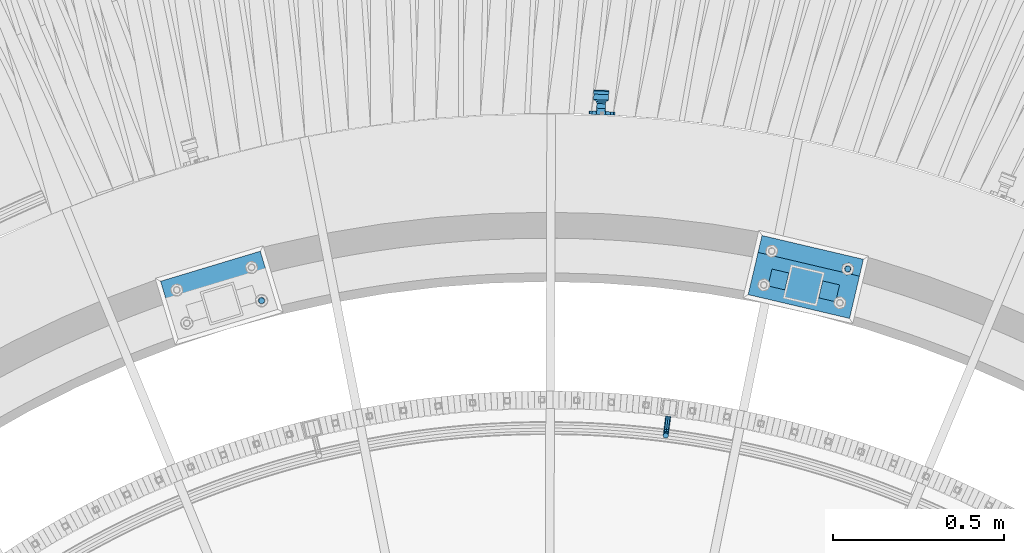
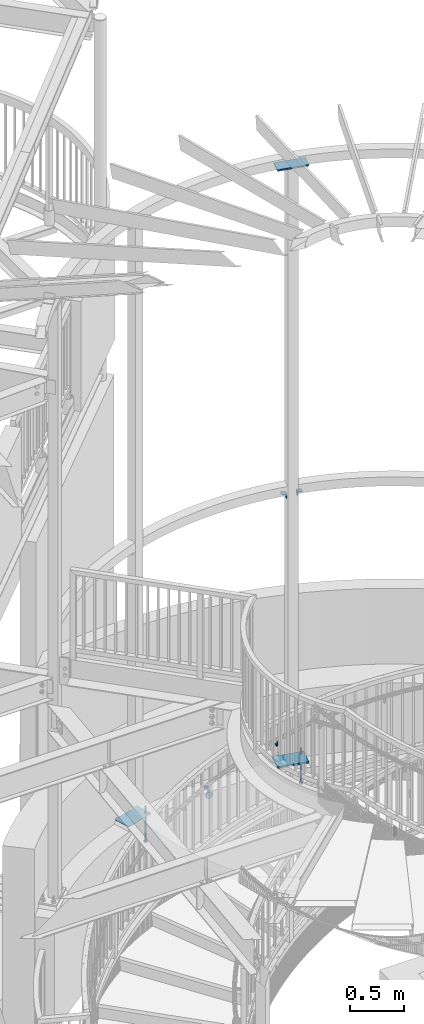
# One storey, part 516 of 975: 9 beams.
"""IFC2X3 building model written with IfcOpenShell, lengths in millimetres."""

from ifc_helpers import new_model, si_unit, frame, origin_with_axes, place, context, subcontext, project, spatial, faceted_brep, material, type_object, element, save


model = new_model("IFC2X3")

# Units and contexts
model_context = context("Model", 3, precision=1e-05, world=origin_with_axes())
body_context = subcontext(model_context, "Body", "Model", "MODEL_VIEW")
ifc_project = project(units=[si_unit("LENGTHUNIT", "METRE", prefix="MILLI"), si_unit("AREAUNIT", "SQUARE_METRE"), si_unit("VOLUMEUNIT", "CUBIC_METRE"), si_unit("MASSUNIT", "GRAM", prefix="KILO"), si_unit("TIMEUNIT", "SECOND"), si_unit("PLANEANGLEUNIT", "RADIAN"), si_unit("SOLIDANGLEUNIT", "STERADIAN"), si_unit("THERMODYNAMICTEMPERATUREUNIT", "DEGREE_CELSIUS"), si_unit("LUMINOUSINTENSITYUNIT", "LUMEN")], contexts=[model_context])

# Site, building, storey
site_placement = place(None, origin_with_axes())
site = spatial("IfcSite", under=ifc_project, at=site_placement, CompositionType="ELEMENT")
building_placement = place(site_placement, origin_with_axes())
building = spatial("IfcBuilding", under=site, at=building_placement, Name="Undefined", CompositionType="ELEMENT")
storey_placement = place(building_placement, origin_with_axes())
storey = spatial("IfcBuildingStorey", under=building, at=storey_placement, Name="Undefined", CompositionType="ELEMENT", Elevation=0.0)

# Beams
ifc_material_1 = material(Name="STEEL/A36")
beam_type_1 = type_object("IfcBeamType", PredefinedType="NOTDEFINED")
beam_1_placement = place(storey_placement, frame((35090.0909619197, 6226.08863746307, 1991.9523874386), z_axis=(0.0, 0.0, 1.0), x_axis=(-0.12548021699091, -0.992096121927666, 0.0)))
element("IfcBeam", 1, at=beam_1_placement, inside=storey, type_object=beam_type_1, material=ifc_material_1, Name="BRACKET", context=body_context, shape_type="Brep", body=[
    faceted_brep([(-4.22995071858168e-07, -7.93750000000728, 0.0), (-2.99107341561466e-07, -5.61266007567065, -5.61266007566792), (31.7499842270954, -5.6126618385606, -5.6126600757234), (31.7499840980236, -7.93750176289177, -5.54791768081486e-11), (-1.09139364212751e-11, 1.81898940354586e-12, -7.9375), (31.7499845387247, -1.7628881323617e-06, -7.93750000005548), (2.99089151667431e-07, 5.61266007567428, -5.61266007566792), (31.7499848503612, 5.61265831278433, -5.6126600757234), (4.22980519942939e-07, 7.93750000001091, 0.0), (31.7499849794513, 7.93749823711914, -5.54791768081486e-11), (2.99089151667431e-07, 5.61266007567428, 5.61266007566792), (31.7499848503794, 5.61265831278433, 5.61266007561244), (-1.09139364212751e-11, 1.81898940354586e-12, 7.9375), (31.7499845387538, -1.7628881323617e-06, 7.93749999994452), (-2.99107341561466e-07, -5.61266007567065, 5.61266007566792), (31.7499842271172, -5.6126618385606, 5.61266007561244), (44.5076933192395, -2.47124626184814e-06, -5.39983394420233), (43.618015285665, -5.61266249752225, -3.25196192174644), (41.4701431341346, -7.93750230259684, 1.9334598451087), (39.322271240766, -5.61266225900181, 7.11888161196475), (38.432593830461, -2.1339365048334e-06, 9.26675363442064), (39.3222718640282, 5.61265789233948, 7.11888161196475), (41.4701440155623, 7.93749769741771, 1.9334598451087), (43.6180159089272, 5.61265765382268, -3.25196192174644), (53.6792468227941, 5.61265709518557, 3.47073764605557), (55.32315658683, -3.07176742353477e-06, 1.82682757038583), (49.7104969518768, 7.93749723988003, 7.43948764606012), (45.7417468228014, 5.61265753590487, 11.4082376460638), (44.0978364355033, -2.44848706643097e-06, 13.0521477217335), (45.7417461995356, -5.61266261544006, 11.4082376460638), (49.7104960704528, -7.93750276013816, 7.43948764606012), (53.6792461995283, -5.612663056163, 3.47073764605648), (60.4019463906188, 5.61265672191075, 13.5319685599115), (62.5498181014409, -3.47302193404175e-06, 12.6422908379673), (55.2165247528465, 7.93749693416248, 15.6798405823693), (50.0311028569122, 5.61265729774459, 17.8277126048279), (47.8832305228243, -2.65866765403189e-06, 18.7173903267721), (50.03110223365, -5.61266285360034, 17.8277126048279), (55.2165238714188, -7.93750306585207, 15.6798405823693), (60.4019457673567, -5.61266342943782, 13.5319685599115), (62.7626445446149, 5.61265659083438, 25.3999996184748), (65.0874841573168, -3.61392449121922e-06, 25.3999996184748), (57.1499845980288, 7.93749682680573, 25.3999996184748), (51.5373243932772, 5.61265721410746, 25.3999996184748), (49.2124841573132, -2.73247496807016e-06, 25.3999996184748), (51.5373237700151, -5.61266293723384, 25.3999996184748), (57.1499837166011, -7.93750317320519, 25.3999996184748), (62.7626439213527, -5.61266356051055, 25.3999996184748), (65.0874827799671, -8.13710357761011e-07, 63.5532656203741), (62.7626427854739, -5.61266086031537, 61.7133802904182), (57.1499826807376, -7.93750071448449, 60.9512776088477), (51.5373226341253, -5.61266071998034, 61.7133869906074), (49.2124827799453, -6.15244061918929e-07, 63.5532750958728), (51.5373227744385, 5.61265943136095, 65.3931604258296), (57.1499828791711, 7.93749928552643, 66.1552631073992), (62.7626429257907, 5.61265929102228, 65.3931537256394)], [[[0, 1, 2, 3]], [[1, 4, 5, 2]], [[4, 6, 7, 5]], [[6, 8, 9, 7]], [[8, 10, 11, 9]], [[10, 12, 13, 11]], [[12, 14, 15, 13]], [[14, 0, 3, 15]], [[14, 12, 10, 8, 6, 4, 1, 0]], [[2, 5, 16, 17]], [[3, 2, 17, 18]], [[15, 3, 18, 19]], [[13, 15, 19, 20]], [[11, 13, 20, 21]], [[9, 11, 21, 22]], [[7, 9, 22, 23]], [[5, 7, 23, 16]], [[23, 24, 25, 16]], [[22, 26, 24, 23]], [[21, 27, 26, 22]], [[20, 28, 27, 21]], [[19, 29, 28, 20]], [[18, 30, 29, 19]], [[17, 31, 30, 18]], [[16, 25, 31, 17]], [[24, 32, 33, 25]], [[26, 34, 32, 24]], [[27, 35, 34, 26]], [[28, 36, 35, 27]], [[29, 37, 36, 28]], [[30, 38, 37, 29]], [[31, 39, 38, 30]], [[25, 33, 39, 31]], [[32, 40, 41, 33]], [[34, 42, 40, 32]], [[35, 43, 42, 34]], [[36, 44, 43, 35]], [[37, 45, 44, 36]], [[38, 46, 45, 37]], [[39, 47, 46, 38]], [[33, 41, 47, 39]], [[47, 41, 48, 49]], [[46, 47, 49, 50]], [[45, 46, 50, 51]], [[44, 45, 51, 52]], [[43, 44, 52, 53]], [[42, 43, 53, 54]], [[40, 42, 54, 55]], [[41, 40, 55, 48]], [[54, 53, 52, 51, 50, 49, 48, 55]]]),
])
beam_type_2 = type_object("IfcBeamType", PredefinedType="NOTDEFINED")
beam_2_placement = place(storey_placement, frame((34896.7817644496, 7118.03903297285, 938.701999049643), z_axis=(-0.996269882339371, 0.0421903820143261, -0.0752747846823936), x_axis=(-0.0423124779877496, -0.999104425706037, 2.72239999873893e-05)))
element("IfcBeam", 2, at=beam_2_placement, inside=storey, type_object=beam_type_2, material=ifc_material_1, Name="WALL BRACKET", context=body_context, shape_type="Brep", body=[
    faceted_brep([(-1.09139364212751e-11, -35.1998101886752, 14.5802387730655), (0.0, -26.940768363208, 26.9407683632162), (1.2732925824821e-11, -14.5802387731151, 35.1998101887366), (0.0, 0.0, 38.0999984741211), (3.27418092638254e-11, 14.5802387730973, 35.1998101888166), (3.45607986673713e-11, 26.9407683631939, 26.9407683633472), (3.27418092638254e-11, 35.1998101886679, 14.5802387732328), (2.36468622460961e-11, 38.0999999999908, 8.73114913702011e-11), (1.45519152283669e-11, 35.1998101886752, -14.5802387730655), (1.81898940354586e-12, 26.9407683632071, -26.9407683632162), (-1.09139364212751e-11, 14.5802387731146, -35.1998101887511), (0.0, 0.0, -38.0999984741211), (-2.91038304567337e-11, -14.5802387730978, -35.1998101888239), (-3.27418092638254e-11, -26.9407683631948, -26.9407683633617), (-3.09228198602796e-11, -35.1998101886688, -14.5802387732401), (-2.36468622460961e-11, -38.0999999999917, -9.45874489843845e-11), (9.52499999999407, 35.4440469783465, 13.3523775149006), (9.52500000001783, 38.099999999989, 1.23691279441118e-10), (5.45819490078651, 35.1998101886775, 14.58023877304), (5.15915812204861, 35.4440469814256, 13.3523774994246), (5.15916016817869, 35.4440461871586, -13.3523814925829), (5.45819607316758, 35.1998101886757, -14.5802387731565), (9.52499999563867, 35.4440461839649, -13.352381508641), (9.52499999999338, 33.7468954266617, -16.754679378646), (9.52499999999418, 26.9407683632057, -26.9407683631944), (7.23710514487385, 33.7468954167059, -16.7546793935435), (9.52499999997963, 14.5802387731133, -35.199810188722), (9.52499999996871, 7.73070496506989e-12, -38.1000000000931), (9.52499999996326, -14.5802387730996, -35.1998101888021), (9.52499999995962, -26.9407683631966, -26.9407683633399), (9.5249999999578, -35.1998101886768, -14.5802387731064), (9.52499999997235, -38.0999999999935, -7.27595761418343e-11), (9.52499999988504, -35.1998101886779, 14.5802387731401), (9.52499999999418, -26.9407683632098, 26.940768363238), (9.52500000000691, -14.5802387731169, 35.1998101887584), (9.52500000001783, -1.13686837721616e-11, 38.1000000001295), (9.5250000000251, 14.580238773096, 35.1998101888312), (9.52500000002692, 26.9407683631925, 26.9407683633617), (7.23710629084189, 33.7468933804012, 16.7546824409801), (9.52500001802099, 33.74689339, 16.7546824266137), (4.12737783423069, 36.2867482851609, 11.6630037101459), (9.52500001480979, 36.2867482910076, 11.6630037099276), (1.9072828969438, 38.0999998001848, -4.3824766180478e-06), (9.43529109937867, 38.0999998083389, -4.38277129433118e-06), (4.12738199474541, 36.2867456530334, -11.6630120660157), (9.52499999713365, 36.2867456588801, -11.6630120662267), (9.52499998931302, 31.8782691818908, -20.5007361535354), (1.90728516843444, 38.0999984362613, -14.9620414784949), (9.43529504267332, 38.0999984471014, -14.9620414798228), (9.52499998867484, 31.8782692100656, -21.3428983101403), (-0.974480980704527, 40.4536660864392, -13.6176374922397), (6.55352889353486, 40.4536660972792, -13.617637493564), (-3.23293929398841, 48.4467136552532, -12.2071016444133), (-3.86099316375032, 48.9596734302611, -12.3332393299024), (-3.86099415506237, 48.9596734359397, 12.1506042690053), (-3.23294234398753, 48.4467162038179, 12.0244673261113), (6.55352388489973, 40.4536689343606, 13.4350048968336), (9.4352891744017, 38.1000015670843, 14.7794093900302), (-8.88876894391092, 51.462646060533, -12.9487245784876), (-14.5044020842531, 51.5524567377918, -12.9708091785214), (-14.5044031272276, 51.5524567437842, 12.788173508583), (-8.88876998507754, 51.4626460665079, 12.7660889411018), (-16.4483770195459, 51.1442726592504, -12.8704360163174), (-16.4483780543928, 51.1442726651987, 12.6878004343525), (-22.5793182144077, 51.3711360271759, -12.9262221073186), (-22.5793192537777, 51.3711360331463, 12.7435864607032), (-27.8885284154861, 54.4455780358899, -13.6822326528272), (-27.8885295160832, 54.4455780422152, 13.4995963000001), (-28.6196515649072, 55.6169452716154, -13.9702738582564), (-31.1370083013608, 59.6501226213948, -17.5950925222933), (-31.1370097188383, 59.6501226295447, 17.4124524185645), (-28.6196545294583, 55.616948227025, 13.7876379643458), (-33.6296792490059, 67.324805151891, -22.2250062266612), (-32.8101722890036, 64.8016260361878, -22.2250061928717), (-39.3161821982224, 64.9509398614337, -22.2250064563596), (-33.6296810489844, 67.3248051619378, 22.2249937734341), (-39.3127719838823, 64.95236112884, 22.2249935438595), (-32.8101756191698, 64.8016307577993, 22.2249938072164), (-49.8281982508399, 63.7590297560901, -21.2879733583577), (-49.8281999673757, 63.7590297658239, 21.1053316176076), (-62.537662592724, 64.8016282183019, -22.2250073966388), (-62.5376643923654, 64.8016282284259, 22.2249926034456), (-59.3629825026719, 68.3509998487543, 22.2249927311568), (-59.3629807030303, 68.3509998386305, -22.2250072689349), (-56.0005505059879, 61.6533412669896, 22.2249928688907), (-56.0009816237271, 61.6535489521873, 19.2130312653135), (-56.0009816302269, 64.8016307505561, 22.0423689734525), (-51.9930603186979, 64.8016307660225, 22.2249930304133), (-51.9930486616773, 64.8016260085653, -22.2250069696784), (-56.000981616694, 61.6535497473442, -22.2250071312228), (-56.0009816212363, 64.8016260027941, -22.2250068759422), (-56.0009816161877, 61.6535496925769, -19.3956728877092), (-50.6240356350016, 59.0640018412871, -17.0683164176735), (-50.6240370098228, 59.0640018490833, 16.8856764812081), (-37.4851004069614, 60.555058921409, -18.4084041452843), (-37.4851018904596, 60.555058929803, 18.2257636742615), (-36.5628425975134, 60.9400579463424, -18.7544220673662), (-36.5628441090176, 60.9400579547794, 18.5717814508498), (-35.6661101826384, 58.1791091500552, -16.2730189810172), (-35.6661114930633, 58.1791091575863, 16.0903794298065), (-34.0669073739811, 55.616948225869, 13.7876379531408), (-34.0669044052501, 55.6169452637716, -13.9702738572996), (-31.199578137138, 51.0230652214489, -12.8406309028251), (-31.1995791695818, 51.0230652273826, 12.6579953160217), (-13.5258453474495, 46.8920843628518, -12.4814476045976), (-10.0158535806146, 46.8359491542703, -12.491353805628), (-10.0158545847443, 46.8359491600327, 12.308720278641), (-13.5258463507973, 46.8920843686235, 12.298814059428), (-15.4698202757649, 46.4839002842855, -12.5534799881534), (-15.469821284944, 46.4839002900824, 12.3708465294185), (-23.8996230795056, 46.7958284847284, -12.4984339079674), (-23.8996240842331, 46.7958284904998, 12.3158003666576), (-26.7505131823156, 48.4467136213889, -12.207101640266), (-26.7505186046602, 48.4467161988273, 12.0244672777189), (-6.87329577845111, 45.2714927334573, -12.7674339683217), (-6.87329680492121, 45.2714927393397, 12.584800790275), (-0.974485553301008, 40.4536689327629, 13.4350048813394), (1.90728014135857, 38.100001565487, 14.7794093745397), (9.52500002100476, 31.8782677827221, 21.320715892205), (9.52500002038346, 31.878267810155, 20.5007393728483)], [[[0, 1, 2, 3, 4, 5, 6, 7, 8, 9, 10, 11, 12, 13, 14, 15]], [[16, 17, 7, 6, 18, 19]], [[20, 21, 8, 7, 17, 22]], [[23, 24, 9, 8, 21, 25]], [[10, 9, 24, 26]], [[11, 10, 26, 27]], [[12, 11, 27, 28]], [[13, 12, 28, 29]], [[14, 13, 29, 30]], [[15, 14, 30, 31]], [[0, 15, 31, 32]], [[1, 0, 32, 33]], [[2, 1, 33, 34]], [[3, 2, 34, 35]], [[4, 3, 35, 36]], [[5, 4, 36, 37]], [[38, 18, 6, 5, 37, 39]], [[39, 37, 36, 35, 34, 33, 32, 31, 30, 29, 28, 27, 26, 24, 23, 22, 17, 16]], [[40, 41, 16, 19]], [[40, 42, 43, 41]], [[42, 44, 45, 43]], [[46, 23, 25]], [[47, 48, 49]], [[48, 47, 50, 51]], [[51, 52, 53, 54, 55, 56, 57, 48]], [[58, 59, 60, 61]], [[59, 62, 63, 60]], [[62, 64, 65, 63]], [[64, 66, 67, 65]], [[66, 68, 69, 70, 71, 67]], [[72, 73, 74]], [[75, 76, 77]], [[74, 76, 75, 72]], [[74, 78, 79, 76]], [[80, 81, 82, 83]], [[84, 85, 86]], [[82, 81, 84, 86, 87]], [[78, 88, 83, 82, 87, 79]], [[89, 80, 83, 88, 90]], [[89, 90, 91]], [[84, 81, 80, 89, 91, 92, 93, 85]], [[92, 94, 95, 93]], [[94, 96, 97, 95]], [[96, 98, 99, 97]], [[70, 77, 76, 79, 87, 86, 85, 93, 95, 97, 99, 100, 71]], [[69, 73, 72, 75, 77, 70]], [[68, 101, 98, 96, 94, 92, 91, 90, 88, 78, 74, 73, 69]], [[99, 98, 101, 102, 103, 100]], [[104, 105, 106, 107]], [[108, 104, 107, 109]], [[110, 108, 109, 111]], [[103, 102, 112, 110, 111, 113]], [[54, 61, 60, 63, 65, 67, 71, 100, 103, 113, 55]], [[53, 58, 61, 54]], [[52, 112, 102, 101, 68, 66, 64, 62, 59, 58, 53]], [[51, 50, 114, 105, 104, 108, 110, 112, 52]], [[105, 114, 115, 106]], [[55, 113, 111, 109, 107, 106, 115, 116, 56]], [[56, 116, 117, 57]], [[117, 118, 57]], [[39, 16, 41, 43, 45, 22, 23, 46, 49, 48, 57, 118, 119]], [[119, 38, 39]], [[119, 118, 117, 116, 115, 114, 50, 47, 49, 46, 25, 21, 20, 44, 42, 40, 19, 18, 38]], [[45, 44, 20, 22]]]),
])
beam_type_3 = type_object("IfcBeamType", Name="L2X2X1/4", PredefinedType="NOTDEFINED")
for number, where, z_axis, x_axis, name in (
    (3, (35555.2744478993, 6566.81264058358, 4445.0), (0.973539033329667, -0.228520788077446, 0.0), (0.228520788077446, 0.973539033329667, 0.0), "ANGLE"),
    (4, (35418.5159552542, 6651.09499157972, 4445.0), (-0.973539033329667, 0.228520788077446, 0.0), (-0.228520788077446, -0.973539033329667, 0.0), "ANGLE"),
):
    element("IfcBeam", number, at=place(storey_placement, frame(where, z_axis=z_axis, x_axis=x_axis)), inside=storey, type_object=beam_type_3, material=ifc_material_1, Name=name, ObjectType="L2X2X1/4", context=body_context, shape_type="Brep", body=[
        faceted_brep([(0.0, 25.3999999999724, -25.4000000000342), (0.0, 25.400000000016, 25.4000000000196), (50.8000000000102, 25.3999999999996, 25.4000000000015), (50.7999999999411, 25.3999999999996, -25.4000000000487), (3.27418092638254e-11, 19.0500000000002, 25.4000000000269), (50.8000000000102, 19.0500000000002, 25.4000000000015), (-2.5465851649642e-11, 19.0500000000002, -19.0500000000211), (50.7999999999483, 19.0500000000002, -19.0500000000429), (-2.5465851649642e-11, -25.3999999999996, -19.0500000000211), (50.7999999999483, -25.3999999999996, -19.0500000000429), (0.0, -25.400000000016, -25.4000000000196), (50.7999999999411, -25.3999999999996, -25.4000000000487)], [[[0, 1, 2, 3]], [[1, 4, 5, 2]], [[4, 6, 7, 5]], [[6, 8, 9, 7]], [[8, 10, 11, 9]], [[10, 0, 3, 11]], [[5, 7, 9, 11, 3, 2]], [[10, 8, 6, 4, 1, 0]]]),
    ])
beam_type_4 = type_object("IfcBeamType", PredefinedType="NOTDEFINED")
beam_3_placement = place(storey_placement, frame((35338.5278528971, 6643.78038418476, 8170.8625), z_axis=(-0.228520788077446, -0.973539033329667, 0.0), x_axis=(0.973539033329667, -0.228520788077446, 0.0)))
element("IfcBeam", 5, at=beam_3_placement, inside=storey, type_object=beam_type_4, material=ifc_material_1, Name="PLATE", context=body_context, shape_type="Brep", body=[
    faceted_brep([(0.0, 7.9375, -63.5), (0.0, 7.9375, 63.5), (304.799999999529, 7.9375, 63.5), (304.799999999529, 7.9375, -63.5), (0.0, -7.9375, 63.5), (304.799999999529, -7.9375, 63.5), (0.0, -7.9375, -63.5), (304.799999999529, -7.9375, -63.5)], [[[0, 1, 2, 3]], [[1, 4, 5, 2]], [[4, 6, 7, 5]], [[6, 0, 3, 7]], [[5, 7, 3, 2]], [[6, 4, 1, 0]]]),
])
ifc_material_2 = material(Name="STEEL/F1554-36")
beam_type_5 = type_object("IfcBeamType", PredefinedType="NOTDEFINED")
beam_4_placement = place(storey_placement, frame((35615.5839971369, 6657.01756434434, 1371.6), z_axis=(-0.973539033329667, 0.228520788077446, 0.0), x_axis=(0.0, 0.0, -1.0)))
element("IfcBeam", 6, at=beam_4_placement, inside=storey, type_object=beam_type_5, material=ifc_material_2, Name="HEADED_ANCHOR_BOLT", context=body_context, shape_type="Brep", body=[
    faceted_brep([(260.34375, -9.13000011445183, 15.8100004195221), (260.34375, -18.2600002289691, -1.45519152283669e-11), (279.393749999999, -18.2600002289691, -1.45519152283669e-11), (279.393749999999, -9.13000011445183, 15.8100004195221), (260.34375, 9.13000011451732, 15.8100004195403), (279.393749999999, 9.13000011451732, 15.8100004195403), (260.34375, 18.2600002289728, 1.81898940354586e-11), (279.393749999999, 18.2600002289728, 1.81898940354586e-11), (260.34375, 9.13000011445547, -15.8100004195221), (279.393749999999, 9.13000011445547, -15.8100004195221), (260.34375, -9.13000011451732, -15.8100004195367), (279.393749999999, -9.13000011451732, -15.8100004195367), (260.34375, -4.47768005528269, 9.29799844174704), (260.34375, -8.06850066050174, 6.43441456486471), (260.34375, -10.0612557562381, 2.29641597050068), (260.34375, -10.0612557562454, -2.29641597051523), (260.34375, -8.06850066052721, -6.43441456487926), (260.34375, -4.47768005531907, -9.29799844175068), (260.34375, -1.81898940354586e-11, -10.319999694766), (260.34375, 4.47768005528633, -9.2979984417434), (260.34375, 8.06850066050174, -6.43441456486471), (260.34375, 10.0612557562381, -2.29641597050068), (260.34375, 10.0612557562454, 2.29641597051886), (260.34375, 8.06850066052357, 6.4344145648829), (260.34375, 4.47768005532271, 9.29799844175432), (260.34375, 2.18278728425503e-11, 10.3199996947696), (279.393749999999, 2.18278728425503e-11, 10.3199996947696), (279.393749999999, -4.47768005528269, 9.29799844174704), (279.393749999999, -8.06850066050174, 6.43441456486471), (279.393749999999, -10.0612557562381, 2.29641597050068), (279.393749999999, -10.0612557562454, -2.29641597051523), (279.393749999999, -8.06850066052721, -6.43441456487926), (279.393749999999, -4.47768005531907, -9.29799844175068), (279.393749999999, -1.81898940354586e-11, -10.319999694766), (279.393749999999, 4.47768005528633, -9.2979984417434), (279.393749999999, 8.06850066050174, -6.43441456486471), (279.393749999999, 10.0612557562381, -2.29641597050068), (279.393749999999, 10.0612557562454, 2.29641597051886), (279.393749999999, 8.06850066052357, 6.4344145648829), (279.393749999999, 4.47768005532271, 9.29799844175432), (0.0, -6.73519209080223, 6.73519209080186), (0.0, -9.52499999999964, 0.0), (279.400000000001, -9.52499999999782, -3.63797880709171e-12), (279.400000000001, -6.73519209079313, 6.73519209079313), (-9.87109982941227e-13, -1.20792265079217e-13, 9.52499961853027), (279.400000000001, 1.09139364212751e-11, 9.52499999999054), (0.0, 6.73519209080223, 6.73519209080186), (279.400000000001, 6.73519209081132, 6.73519209079677), (0.0, 9.52499999999964, 0.0), (279.400000000001, 9.52500000000146, 3.63797880709171e-12), (0.0, 6.73519209080223, -6.73519209080186), (279.400000000001, 6.73519209079677, -6.73519209079313), (2.95075507493764e-12, -1.20792265079217e-13, -9.52499961853027), (279.400000000001, -1.09139364212751e-11, -9.5249999999869), (-126.99791499542, -6.36396103070001, 6.3639610306418), (-126.99791499542, 1.81898940354586e-11, 8.99999999995271), (-126.99791499542, 6.36396103072184, 6.36396103065272), (-126.99791499542, 9.00000000004366, 1.09139364212751e-11), (-126.99791499542, 6.36396103069637, -6.3639610306418), (-126.99791499542, -1.81898940354586e-11, -8.99999999995271), (-126.99791499542, -6.36396103072184, -6.36396103064908), (-126.99791499542, -9.00000000004002, -7.27595761418343e-12), (0.0149743263646087, 6.36396103067818, -6.36396103067909), (0.0149743263646087, 0.0, -9.0), (0.0149743263646087, -6.36396103067818, -6.36396103067909), (0.0149743263987148, -8.9999995411581, -1.00796984270346e-06), (0.0149743263646087, -6.36396103067818, 6.36396103067909), (0.0149743263646087, 0.0, 9.0), (0.0149743263646087, 6.36396103067818, 6.36396103067909), (0.0149743263987148, 9.0000004588419, -1.00796984270346e-06), (0.0, -6.73519209080223, -6.73519209080186), (279.400000000001, -6.73519209080769, -6.73519209079677)], [[[0, 1, 2, 3]], [[4, 0, 3, 5]], [[6, 4, 5, 7]], [[8, 6, 7, 9]], [[10, 8, 9, 11]], [[0, 4, 6, 8, 10, 1], [12, 13, 14, 15, 16, 17, 18, 19, 20, 21, 22, 23, 24, 25]], [[12, 25, 26, 27]], [[13, 12, 27, 28]], [[14, 13, 28, 29]], [[15, 14, 29, 30]], [[16, 15, 30, 31]], [[17, 16, 31, 32]], [[18, 17, 32, 33]], [[19, 18, 33, 34]], [[20, 19, 34, 35]], [[21, 20, 35, 36]], [[22, 21, 36, 37]], [[23, 22, 37, 38]], [[24, 23, 38, 39]], [[25, 24, 39, 26]], [[9, 7, 5, 3, 2, 11], [38, 37, 36, 35, 34, 33, 32, 31, 30, 29, 28, 27, 26, 39]], [[1, 10, 11, 2]], [[40, 41, 42, 43]], [[44, 40, 43, 45]], [[46, 44, 45, 47]], [[48, 46, 47, 49]], [[50, 48, 49, 51]], [[52, 50, 51, 53]], [[54, 55, 56, 57, 58, 59, 60, 61]], [[59, 58, 62, 63]], [[60, 59, 63, 64]], [[61, 60, 64, 65]], [[54, 61, 65, 66]], [[55, 54, 66, 67]], [[56, 55, 67, 68]], [[57, 56, 68, 69]], [[58, 57, 69, 62]], [[40, 44, 46, 48, 50, 52, 70, 41], [68, 67, 66, 65, 64, 63, 62, 69]], [[41, 70, 71, 42]], [[53, 51, 49, 47, 45, 43, 42, 71]], [[70, 52, 53, 71]]]),
])
beam_5_placement = place(storey_placement, frame((33900.184720342, 6564.41659721454, 1371.6), z_axis=(0.957369928409554, 0.288864709123642, 0.0), x_axis=(0.0, 0.0, -1.0)))
element("IfcBeam", 7, at=beam_5_placement, inside=storey, type_object=beam_type_5, material=ifc_material_2, Name="HEADED_ANCHOR_BOLT", context=body_context, shape_type="Brep", body=[
    faceted_brep([(260.34375, -9.13000011445183, 15.8100004195221), (260.34375, -18.2600002289691, -1.45519152283669e-11), (279.393749999999, -18.2600002289691, -1.45519152283669e-11), (279.393749999999, -9.13000011445183, 15.8100004195221), (260.34375, 9.13000011451732, 15.8100004195403), (279.393749999999, 9.13000011451732, 15.8100004195403), (260.34375, 18.2600002289728, 1.81898940354586e-11), (279.393749999999, 18.2600002289728, 1.81898940354586e-11), (260.34375, 9.13000011445547, -15.8100004195221), (279.393749999999, 9.13000011445547, -15.8100004195221), (260.34375, -9.13000011451732, -15.8100004195367), (279.393749999999, -9.13000011451732, -15.8100004195367), (260.34375, -4.47768005528269, 9.29799844174704), (260.34375, -8.06850066050174, 6.43441456486471), (260.34375, -10.0612557562381, 2.29641597050068), (260.34375, -10.0612557562454, -2.29641597051523), (260.34375, -8.06850066052721, -6.43441456487926), (260.34375, -4.47768005531907, -9.29799844175068), (260.34375, -1.81898940354586e-11, -10.319999694766), (260.34375, 4.47768005528633, -9.2979984417434), (260.34375, 8.06850066050174, -6.43441456486471), (260.34375, 10.0612557562381, -2.29641597050068), (260.34375, 10.0612557562454, 2.29641597051886), (260.34375, 8.06850066052357, 6.4344145648829), (260.34375, 4.47768005532271, 9.29799844175432), (260.34375, 2.18278728425503e-11, 10.3199996947696), (279.393749999999, 2.18278728425503e-11, 10.3199996947696), (279.393749999999, -4.47768005528269, 9.29799844174704), (279.393749999999, -8.06850066050174, 6.43441456486471), (279.393749999999, -10.0612557562381, 2.29641597050068), (279.393749999999, -10.0612557562454, -2.29641597051523), (279.393749999999, -8.06850066052721, -6.43441456487926), (279.393749999999, -4.47768005531907, -9.29799844175068), (279.393749999999, -1.81898940354586e-11, -10.319999694766), (279.393749999999, 4.47768005528633, -9.2979984417434), (279.393749999999, 8.06850066050174, -6.43441456486471), (279.393749999999, 10.0612557562381, -2.29641597050068), (279.393749999999, 10.0612557562454, 2.29641597051886), (279.393749999999, 8.06850066052357, 6.4344145648829), (279.393749999999, 4.47768005532271, 9.29799844175432), (0.0, -6.73519209080223, 6.73519209080186), (0.0, -9.52499999999964, 0.0), (279.400000000001, -9.52499999999782, -3.63797880709171e-12), (279.400000000001, -6.73519209079313, 6.73519209079313), (-9.87109982941227e-13, -1.20792265079217e-13, 9.52499961853027), (279.400000000001, 1.09139364212751e-11, 9.52499999999054), (0.0, 6.73519209080223, 6.73519209080186), (279.400000000001, 6.73519209081132, 6.73519209079677), (0.0, 9.52499999999964, 0.0), (279.400000000001, 9.52500000000146, 3.63797880709171e-12), (0.0, 6.73519209080223, -6.73519209080186), (279.400000000001, 6.73519209079677, -6.73519209079313), (2.95075507493764e-12, -1.20792265079217e-13, -9.52499961853027), (279.400000000001, -1.09139364212751e-11, -9.5249999999869), (-126.99791499542, -6.36396103070001, 6.3639610306418), (-126.99791499542, 1.81898940354586e-11, 8.99999999995271), (-126.99791499542, 6.36396103072184, 6.36396103065272), (-126.99791499542, 9.00000000004366, 1.09139364212751e-11), (-126.99791499542, 6.36396103069637, -6.3639610306418), (-126.99791499542, -1.81898940354586e-11, -8.99999999995271), (-126.99791499542, -6.36396103072184, -6.36396103064908), (-126.99791499542, -9.00000000004002, -7.27595761418343e-12), (0.0149743263646087, 6.36396103067818, -6.36396103067909), (0.0149743263646087, 0.0, -9.0), (0.0149743263646087, -6.36396103067818, -6.36396103067909), (0.0149743263987148, -8.9999995411581, -1.00796984270346e-06), (0.0149743263646087, -6.36396103067818, 6.36396103067909), (0.0149743263646087, 0.0, 9.0), (0.0149743263646087, 6.36396103067818, 6.36396103067909), (0.0149743263987148, 9.0000004588419, -1.00796984270346e-06), (0.0, -6.73519209080223, -6.73519209080186), (279.400000000001, -6.73519209080769, -6.73519209079677)], [[[0, 1, 2, 3]], [[4, 0, 3, 5]], [[6, 4, 5, 7]], [[8, 6, 7, 9]], [[10, 8, 9, 11]], [[0, 4, 6, 8, 10, 1], [12, 13, 14, 15, 16, 17, 18, 19, 20, 21, 22, 23, 24, 25]], [[12, 25, 26, 27]], [[13, 12, 27, 28]], [[14, 13, 28, 29]], [[15, 14, 29, 30]], [[16, 15, 30, 31]], [[17, 16, 31, 32]], [[18, 17, 32, 33]], [[19, 18, 33, 34]], [[20, 19, 34, 35]], [[21, 20, 35, 36]], [[22, 21, 36, 37]], [[23, 22, 37, 38]], [[24, 23, 38, 39]], [[25, 24, 39, 26]], [[9, 7, 5, 3, 2, 11], [38, 37, 36, 35, 34, 33, 32, 31, 30, 29, 28, 27, 26, 39]], [[1, 10, 11, 2]], [[40, 41, 42, 43]], [[44, 40, 43, 45]], [[46, 44, 45, 47]], [[48, 46, 47, 49]], [[50, 48, 49, 51]], [[52, 50, 51, 53]], [[54, 55, 56, 57, 58, 59, 60, 61]], [[59, 58, 62, 63]], [[60, 59, 63, 64]], [[61, 60, 64, 65]], [[54, 61, 65, 66]], [[55, 54, 66, 67]], [[56, 55, 67, 68]], [[57, 56, 68, 69]], [[58, 57, 69, 62]], [[40, 44, 46, 48, 50, 52, 70, 41], [68, 67, 66, 65, 64, 63, 62, 69]], [[41, 70, 71, 42]], [[53, 51, 49, 47, 45, 43, 42, 71]], [[70, 52, 53, 71]]]),
])
beam_type_6 = type_object("IfcBeamType", PredefinedType="NOTDEFINED")
beam_6_placement = place(storey_placement, frame((35344.3322809142, 6668.50827563151, 1419.225), z_axis=(0.228520788077446, 0.973539033329667, 0.0), x_axis=(0.973539033329667, -0.228520788077446, 0.0)))
element("IfcBeam", 8, at=beam_6_placement, inside=storey, type_object=beam_type_6, material=ifc_material_1, Name="PLATE", context=body_context, shape_type="Brep", body=[
    faceted_brep([(0.0, 9.52499999999964, -88.9000000000015), (0.0, 9.52499999999964, 88.9000000000015), (304.800000000429, 9.52500000000009, 88.9000000003653), (304.800000000414, 9.52500000000009, -88.8999999996704), (0.0, -9.52499999999964, 88.9000000000015), (304.800000000429, -9.52500000000009, 88.9000000003653), (0.0, -9.52499999999964, -88.9000000000015), (304.800000000414, -9.52500000000009, -88.8999999996704)], [[[0, 1, 2, 3]], [[1, 4, 5, 2]], [[4, 6, 7, 5]], [[6, 0, 3, 7]], [[5, 7, 3, 2]], [[6, 4, 1, 0]]]),
])
beam_type_7 = type_object("IfcBeamType", PredefinedType="NOTDEFINED")
beam_7_placement = place(storey_placement, frame((33630.1798273669, 6536.0107699428, 1411.2875), z_axis=(-0.288864709123643, 0.957369928409553, 0.0), x_axis=(0.957369928409554, 0.288864709123642, 0.0)))
element("IfcBeam", 9, at=beam_7_placement, inside=storey, type_object=beam_type_7, material=ifc_material_1, Name="TEMPLATE", context=body_context, shape_type="Brep", body=[
    faceted_brep([(-1.09139364212751e-11, 1.58750000000009, -88.900000000016), (3.63797880709171e-12, 1.58750000000009, 88.9000000000196), (304.800000000418, 1.58750000000009, 88.9000000003762), (304.800000000399, 1.58750000000009, -88.8999999996631), (3.63797880709171e-12, -1.58750000000009, 88.9000000000196), (304.800000000418, -1.58750000000009, 88.9000000003762), (-1.09139364212751e-11, -1.58750000000009, -88.900000000016), (304.800000000399, -1.58750000000009, -88.8999999996631)], [[[0, 1, 2, 3]], [[1, 4, 5, 2]], [[4, 6, 7, 5]], [[6, 0, 3, 7]], [[5, 7, 3, 2]], [[6, 4, 1, 0]]]),
])

save(model, "model.ifc")
